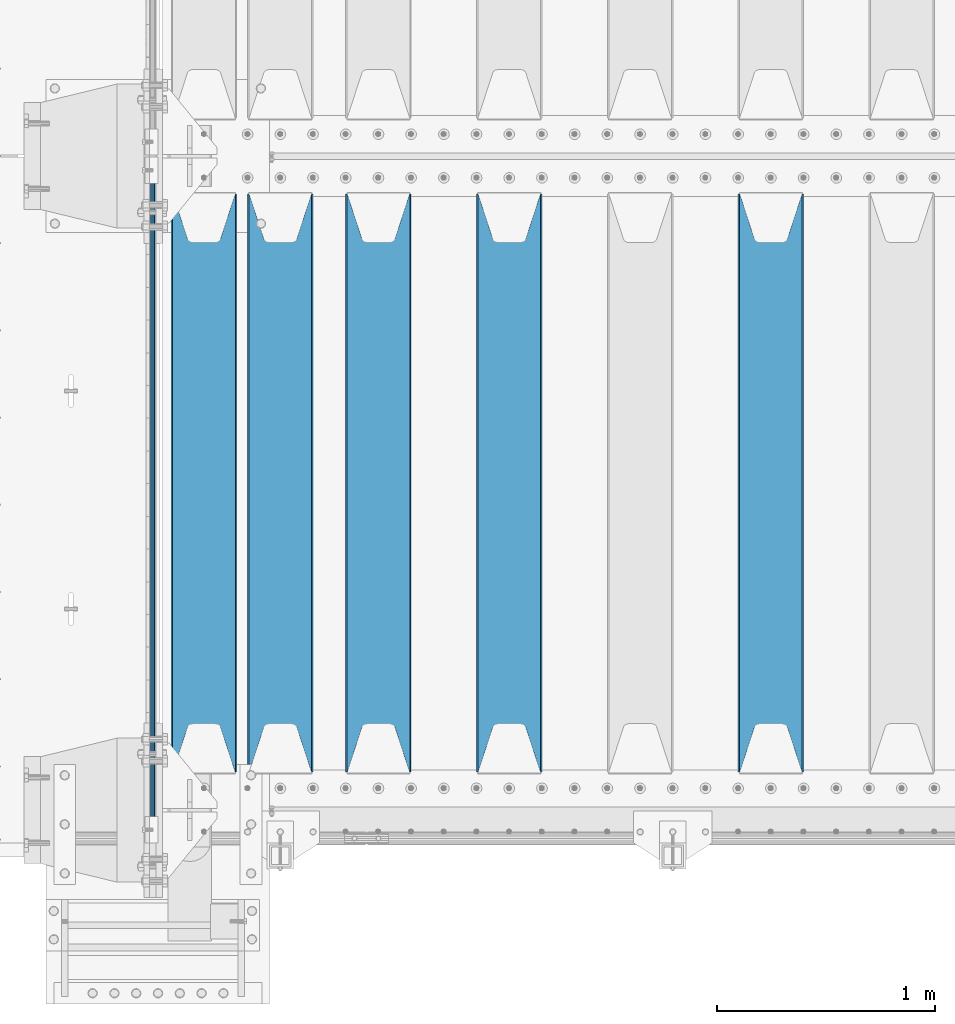
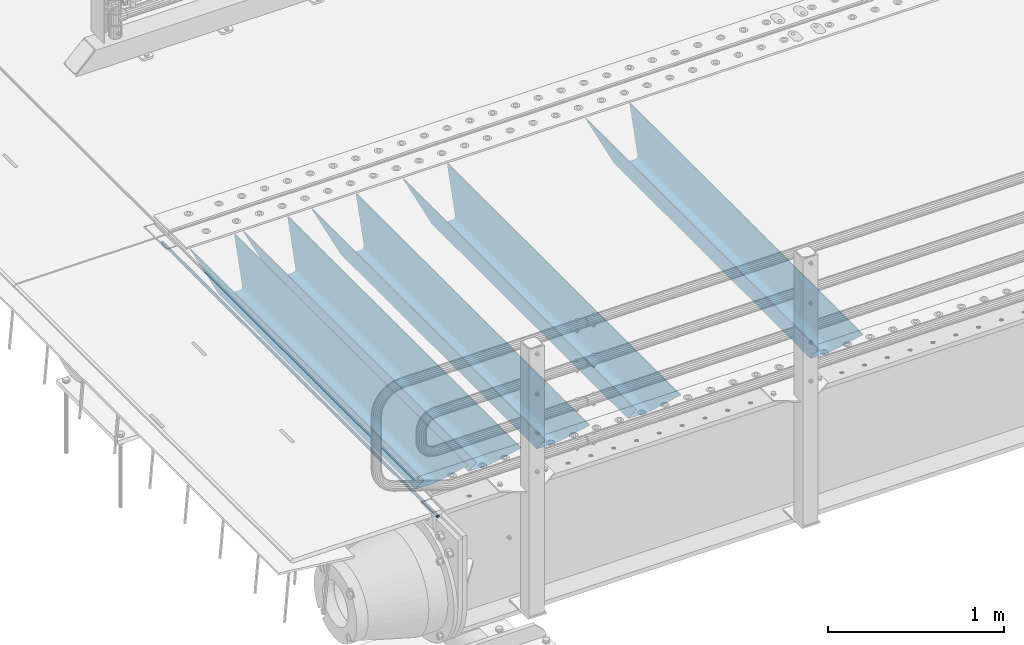
# One storey, part 85 of 193: 6 beams.
"""IFC2X3 building model written with IfcOpenShell, lengths in millimetres."""

from ifc_helpers import new_model, si_unit, frame, origin_with_axes, place, context, subcontext, project, spatial, faceted_brep, material, type_object, element, save


model = new_model("IFC2X3")

# Units and contexts
model_context = context("Model", 3, precision=1e-05, world=origin_with_axes())
body_context = subcontext(model_context, "Body", "Model", "MODEL_VIEW")
ifc_project = project(units=[si_unit("LENGTHUNIT", "METRE", prefix="MILLI"), si_unit("AREAUNIT", "SQUARE_METRE"), si_unit("VOLUMEUNIT", "CUBIC_METRE"), si_unit("MASSUNIT", "GRAM", prefix="KILO"), si_unit("TIMEUNIT", "SECOND"), si_unit("PLANEANGLEUNIT", "RADIAN"), si_unit("SOLIDANGLEUNIT", "STERADIAN"), si_unit("THERMODYNAMICTEMPERATUREUNIT", "DEGREE_CELSIUS"), si_unit("LUMINOUSINTENSITYUNIT", "LUMEN")], contexts=[model_context])

# Site, building, storey
site_placement = place(None, origin_with_axes())
site = spatial("IfcSite", under=ifc_project, at=site_placement, CompositionType="ELEMENT")
building_placement = place(site_placement, origin_with_axes())
building = spatial("IfcBuilding", under=site, at=building_placement, Name="Standard", CompositionType="ELEMENT")
storey_placement = place(building_placement, origin_with_axes())
storey = spatial("IfcBuildingStorey", under=building, at=storey_placement, Name="Undefined", CompositionType="ELEMENT", Elevation=0.0)

# Beams
ifc_material = material(Name="STEEL/S355N")
beam_type_1 = type_object("IfcBeamType", Name="D20", PredefinedType="NOTDEFINED")
beam_1_placement = place(storey_placement, frame((-42485.0, 23850.0, -26.0000191637567), z_axis=(0.0, 0.0, 1.0), x_axis=(0.0, 1.0, 0.0)))
element("IfcBeam", 1, at=beam_1_placement, inside=storey, type_object=beam_type_1, material=ifc_material, ObjectType="D20", context=body_context, shape_type="Brep", body=[
    faceted_brep([(0.0, -10.0, 0.0), (0.0, -7.07106781186303, -7.07106781186548), (3145.0, -7.07106781186303, -7.07106781186548), (3145.0, -10.0, 0.0), (0.0, 0.0, -10.0), (3145.0, 0.0, -10.0), (0.0, 7.07106781186303, -7.07106781186547), (3145.0, 7.07106781186303, -7.07106781186547), (0.0, 10.0, 0.0), (3145.0, 10.0, 0.0), (0.0, 7.07106781186303, 7.07106781186548), (3145.0, 7.07106781186303, 7.07106781186548), (0.0, 0.0, 10.0), (3145.0, 0.0, 10.0), (0.0, -7.07106781186303, 7.07106781186548), (3145.0, -7.07106781186303, 7.07106781186548)], [[[0, 1, 2, 3]], [[1, 4, 5, 2]], [[4, 6, 7, 5]], [[6, 8, 9, 7]], [[8, 10, 11, 9]], [[10, 12, 13, 11]], [[12, 14, 15, 13]], [[14, 0, 3, 15]], [[5, 7, 9, 11, 13, 15, 3, 2]], [[14, 12, 10, 8, 6, 4, 1, 0]]]),
])
beam_type_2 = type_object("IfcBeamType", PredefinedType="NOTDEFINED")
beam_2_placement = place(storey_placement, frame((-39650.0, 24175.0, -115.0), z_axis=(0.0, 0.0, 1.0), x_axis=(0.0, 1.0, 0.0)))
element("IfcBeam", 2, at=beam_2_placement, inside=storey, type_object=beam_type_2, material=ifc_material, context=body_context, shape_type="Brep", body=[
    faceted_brep([(0.0, 150.0, 115.0), (0.0, 143.689999999999, 115.0), (2650.00000000297, 143.689999999999, 115.0), (2650.00000000297, 150.0, 115.0), (2650.00000000297, 142.059565218398, 110.000000003094), (2650.00000000297, 148.3695652184, 110.000000003094), (2441.90079219209, -80.1103600731112, -98.0992078077845), (2437.7588105432, -77.5672621345584, -102.241189456673), (2434.06523489747, -74.4080125315522, -105.934765102404), (2430.9108609509, -70.710272125576, -109.089139048974), (2428.37322971128, -66.5649389910068, -111.626770288588), (2426.51472138055, -62.0739139532889, -113.485278619323), (2425.38102192092, -57.3475956567672, -114.618978078955), (2424.99999999988, -52.5021667386536, -115.0), (2424.99999999988, 52.5021667386536, -115.0), (2425.38102192092, 57.3475956567672, -114.618978078955), (2426.51472138055, 62.0739139532889, -113.485278619323), (2428.37322971128, 66.5649389910068, -111.626770288588), (2430.9108609509, 70.710272125576, -109.089139048974), (2434.06523489747, 74.4080125315522, -105.934765102404), (2437.7588105432, 77.5672621345584, -102.241189456673), (2441.90079219209, 80.1103600731112, -98.0992078077846), (2446.38936140512, 81.9747917625791, -93.6106385947584), (2448.2494850041, 76.2713538057251, -91.7505149957729), (2444.62967112263, 74.76777986261, -95.3703288772456), (2441.28936334127, 72.7168944282894, -98.710636658607), (2438.31067330439, 70.1691124903846, -101.689326695487), (2435.76682334748, 67.1870637758839, -104.233176652398), (2433.72034654134, 63.8440531834895, -106.279653458539), (2432.22154950042, 60.222258798236, -107.778450499454), (2431.30727574265, 56.4107117849089, -108.692724257221), (2430.99999999987, 52.5031078186876, -109.0), (2430.99999999987, -52.5031078186876, -109.0), (2431.30727574265, -56.4107117849089, -108.692724257221), (2432.22154950042, -60.222258798236, -107.778450499454), (2433.72034654134, -63.8440531834895, -106.279653458539), (2435.76682334748, -67.1870637758839, -104.233176652398), (2438.31067330439, -70.1691124903846, -101.689326695487), (2441.28936334127, -72.7168944282894, -98.7106366586071), (2444.62967112263, -74.76777986261, -95.3703288772457), (2448.2494850041, -76.2713538057251, -91.7505149957729), (2650.00000000297, -142.059565218398, 110.000000003094), (2650.00000000297, -148.3695652184, 110.000000003094), (2446.38936140512, -81.9747917625791, -93.6106385947584), (2650.00000000297, -143.689999999999, 115.0), (2650.00000000297, -150.0, 115.0), (0.0, -143.689999999999, 115.0), (0.0, -150.0, 115.0), (0.0, -148.369565218261, 110.000000002667), (203.610638597427, -81.9747917625791, -93.6106385947584), (208.099207810446, -80.1103600731112, -98.0992078077845), (212.241189459342, -77.5672621345584, -102.241189456673), (215.93476510507, -74.4080125315522, -105.934765102404), (219.089139051641, -70.710272125576, -109.089139048974), (221.626770291256, -66.5649389910068, -111.626770288588), (223.485278621989, -62.0739139532889, -113.485278619323), (224.618978081624, -57.3475956567672, -114.618978078955), (225.000000002663, -52.5021667386536, -115.0), (225.000000002663, 52.5021667386536, -115.0), (224.618978081624, 57.3475956567672, -114.618978078955), (223.485278621989, 62.0739139532889, -113.485278619323), (221.626770291256, 66.5649389910068, -111.626770288588), (219.089139051641, 70.710272125576, -109.089139048974), (215.93476510507, 74.4080125315522, -105.934765102404), (212.241189459342, 77.5672621345584, -102.241189456673), (208.099207810446, 80.1103600731112, -98.0992078077846), (203.610638597427, 81.9747917625791, -93.6106385947584), (0.0, 148.369565218261, 110.000000002667), (0.0, 142.05956521826, 110.000000002667), (201.750514998439, 76.2713538057251, -91.7505149957729), (205.370328879915, 74.76777986261, -95.3703288772456), (208.710636661275, 72.7168944282894, -98.710636658607), (211.689326698157, 70.1691124903846, -101.689326695487), (214.233176655063, 67.1870637758839, -104.233176652398), (216.279653461206, 63.8440531834895, -106.279653458539), (217.778450502123, 60.222258798236, -107.778450499454), (218.69272425989, 56.4107117849089, -108.692724257221), (219.00000000267, 52.5031078186876, -109.0), (219.00000000267, -52.5031078186876, -109.0), (218.69272425989, -56.4107117849089, -108.692724257221), (217.778450502123, -60.222258798236, -107.778450499454), (216.279653461206, -63.8440531834895, -106.279653458539), (214.233176655063, -67.1870637758839, -104.233176652398), (211.689326698157, -70.1691124903846, -101.689326695487), (208.710636661275, -72.7168944282894, -98.7106366586071), (205.370328879915, -74.76777986261, -95.3703288772457), (201.750514998439, -76.2713538057251, -91.7505149957729), (0.0, -142.05956521826, 110.000000002667)], [[[0, 1, 2, 3]], [[3, 2, 4, 5]], [[6, 7, 8, 9, 10, 11, 12, 13, 14, 15, 16, 17, 18, 19, 20, 21, 22, 5, 4, 23, 24, 25, 26, 27, 28, 29, 30, 31, 32, 33, 34, 35, 36, 37, 38, 39, 40, 41, 42, 43]], [[44, 45, 42, 41]], [[46, 47, 45, 44]], [[43, 42, 45, 47, 48, 49]], [[6, 43, 49, 50]], [[7, 6, 50, 51]], [[8, 7, 51, 52]], [[9, 8, 52, 53]], [[10, 9, 53, 54]], [[11, 10, 54, 55]], [[12, 11, 55, 56]], [[13, 12, 56, 57]], [[14, 13, 57, 58]], [[15, 14, 58, 59]], [[16, 15, 59, 60]], [[17, 16, 60, 61]], [[18, 17, 61, 62]], [[19, 18, 62, 63]], [[20, 19, 63, 64]], [[21, 20, 64, 65]], [[22, 21, 65, 66]], [[0, 3, 5, 22, 66, 67]], [[1, 0, 67, 68]], [[23, 4, 2, 1, 68, 69]], [[24, 23, 69, 70]], [[25, 24, 70, 71]], [[26, 25, 71, 72]], [[27, 26, 72, 73]], [[28, 27, 73, 74]], [[29, 28, 74, 75]], [[30, 29, 75, 76]], [[31, 30, 76, 77]], [[32, 31, 77, 78]], [[33, 32, 78, 79]], [[34, 33, 79, 80]], [[35, 34, 80, 81]], [[36, 35, 81, 82]], [[37, 36, 82, 83]], [[38, 37, 83, 84]], [[39, 38, 84, 85]], [[40, 39, 85, 86]], [[46, 44, 41, 40, 86, 87]], [[47, 46, 87, 48]], [[86, 85, 84, 83, 82, 81, 80, 79, 78, 77, 76, 75, 74, 73, 72, 71, 70, 69, 68, 67, 66, 65, 64, 63, 62, 61, 60, 59, 58, 57, 56, 55, 54, 53, 52, 51, 50, 49, 48, 87]]]),
])
beam_3_placement = place(storey_placement, frame((-40850.0, 24175.0, -115.0), z_axis=(0.0, 0.0, 1.0), x_axis=(0.0, 1.0, 0.0)))
element("IfcBeam", 3, at=beam_3_placement, inside=storey, type_object=beam_type_2, material=ifc_material, context=body_context, shape_type="Brep", body=[
    faceted_brep([(0.0, 150.0, 115.0), (0.0, 143.689999999999, 115.0), (2650.00000000297, 143.689999999999, 115.0), (2650.00000000297, 150.0, 115.0), (2650.00000000297, 142.059565218398, 110.000000003094), (2650.00000000297, 148.3695652184, 110.000000003094), (2441.90079219209, -80.1103600731112, -98.0992078077845), (2437.7588105432, -77.5672621345584, -102.241189456673), (2434.06523489747, -74.4080125315522, -105.934765102404), (2430.9108609509, -70.710272125576, -109.089139048974), (2428.37322971128, -66.5649389910068, -111.626770288588), (2426.51472138055, -62.0739139532889, -113.485278619323), (2425.38102192092, -57.3475956567672, -114.618978078955), (2424.99999999988, -52.5021667386536, -115.0), (2424.99999999988, 52.5021667386536, -115.0), (2425.38102192092, 57.3475956567672, -114.618978078955), (2426.51472138055, 62.0739139532889, -113.485278619323), (2428.37322971128, 66.5649389910068, -111.626770288588), (2430.9108609509, 70.710272125576, -109.089139048974), (2434.06523489747, 74.4080125315522, -105.934765102404), (2437.7588105432, 77.5672621345584, -102.241189456673), (2441.90079219209, 80.1103600731112, -98.0992078077846), (2446.38936140512, 81.9747917625791, -93.6106385947584), (2448.2494850041, 76.2713538057251, -91.7505149957729), (2444.62967112263, 74.76777986261, -95.3703288772456), (2441.28936334127, 72.7168944282894, -98.710636658607), (2438.31067330439, 70.1691124903846, -101.689326695487), (2435.76682334748, 67.1870637758839, -104.233176652398), (2433.72034654134, 63.8440531834895, -106.279653458539), (2432.22154950042, 60.222258798236, -107.778450499454), (2431.30727574265, 56.4107117849089, -108.692724257221), (2430.99999999987, 52.5031078186876, -109.0), (2430.99999999987, -52.5031078186876, -109.0), (2431.30727574265, -56.4107117849089, -108.692724257221), (2432.22154950042, -60.222258798236, -107.778450499454), (2433.72034654134, -63.8440531834895, -106.279653458539), (2435.76682334748, -67.1870637758839, -104.233176652398), (2438.31067330439, -70.1691124903846, -101.689326695487), (2441.28936334127, -72.7168944282894, -98.7106366586071), (2444.62967112263, -74.76777986261, -95.3703288772457), (2448.2494850041, -76.2713538057251, -91.7505149957729), (2650.00000000297, -142.059565218398, 110.000000003094), (2650.00000000297, -148.3695652184, 110.000000003094), (2446.38936140512, -81.9747917625791, -93.6106385947584), (2650.00000000297, -143.689999999999, 115.0), (2650.00000000297, -150.0, 115.0), (0.0, -143.689999999999, 115.0), (0.0, -150.0, 115.0), (0.0, -148.369565218261, 110.000000002667), (203.610638597427, -81.9747917625791, -93.6106385947584), (208.099207810446, -80.1103600731112, -98.0992078077845), (212.241189459342, -77.5672621345584, -102.241189456673), (215.93476510507, -74.4080125315522, -105.934765102404), (219.089139051641, -70.710272125576, -109.089139048974), (221.626770291256, -66.5649389910068, -111.626770288588), (223.485278621989, -62.0739139532889, -113.485278619323), (224.618978081624, -57.3475956567672, -114.618978078955), (225.000000002663, -52.5021667386536, -115.0), (225.000000002663, 52.5021667386536, -115.0), (224.618978081624, 57.3475956567672, -114.618978078955), (223.485278621989, 62.0739139532889, -113.485278619323), (221.626770291256, 66.5649389910068, -111.626770288588), (219.089139051641, 70.710272125576, -109.089139048974), (215.93476510507, 74.4080125315522, -105.934765102404), (212.241189459342, 77.5672621345584, -102.241189456673), (208.099207810446, 80.1103600731112, -98.0992078077846), (203.610638597427, 81.9747917625791, -93.6106385947584), (0.0, 148.369565218261, 110.000000002667), (0.0, 142.05956521826, 110.000000002667), (201.750514998439, 76.2713538057251, -91.7505149957729), (205.370328879915, 74.76777986261, -95.3703288772456), (208.710636661275, 72.7168944282894, -98.710636658607), (211.689326698157, 70.1691124903846, -101.689326695487), (214.233176655063, 67.1870637758839, -104.233176652398), (216.279653461206, 63.8440531834895, -106.279653458539), (217.778450502123, 60.222258798236, -107.778450499454), (218.69272425989, 56.4107117849089, -108.692724257221), (219.00000000267, 52.5031078186876, -109.0), (219.00000000267, -52.5031078186876, -109.0), (218.69272425989, -56.4107117849089, -108.692724257221), (217.778450502123, -60.222258798236, -107.778450499454), (216.279653461206, -63.8440531834895, -106.279653458539), (214.233176655063, -67.1870637758839, -104.233176652398), (211.689326698157, -70.1691124903846, -101.689326695487), (208.710636661275, -72.7168944282894, -98.7106366586071), (205.370328879915, -74.76777986261, -95.3703288772457), (201.750514998439, -76.2713538057251, -91.7505149957729), (0.0, -142.05956521826, 110.000000002667)], [[[0, 1, 2, 3]], [[3, 2, 4, 5]], [[6, 7, 8, 9, 10, 11, 12, 13, 14, 15, 16, 17, 18, 19, 20, 21, 22, 5, 4, 23, 24, 25, 26, 27, 28, 29, 30, 31, 32, 33, 34, 35, 36, 37, 38, 39, 40, 41, 42, 43]], [[44, 45, 42, 41]], [[46, 47, 45, 44]], [[43, 42, 45, 47, 48, 49]], [[6, 43, 49, 50]], [[7, 6, 50, 51]], [[8, 7, 51, 52]], [[9, 8, 52, 53]], [[10, 9, 53, 54]], [[11, 10, 54, 55]], [[12, 11, 55, 56]], [[13, 12, 56, 57]], [[14, 13, 57, 58]], [[15, 14, 58, 59]], [[16, 15, 59, 60]], [[17, 16, 60, 61]], [[18, 17, 61, 62]], [[19, 18, 62, 63]], [[20, 19, 63, 64]], [[21, 20, 64, 65]], [[22, 21, 65, 66]], [[0, 3, 5, 22, 66, 67]], [[1, 0, 67, 68]], [[23, 4, 2, 1, 68, 69]], [[24, 23, 69, 70]], [[25, 24, 70, 71]], [[26, 25, 71, 72]], [[27, 26, 72, 73]], [[28, 27, 73, 74]], [[29, 28, 74, 75]], [[30, 29, 75, 76]], [[31, 30, 76, 77]], [[32, 31, 77, 78]], [[33, 32, 78, 79]], [[34, 33, 79, 80]], [[35, 34, 80, 81]], [[36, 35, 81, 82]], [[37, 36, 82, 83]], [[38, 37, 83, 84]], [[39, 38, 84, 85]], [[40, 39, 85, 86]], [[46, 44, 41, 40, 86, 87]], [[47, 46, 87, 48]], [[86, 85, 84, 83, 82, 81, 80, 79, 78, 77, 76, 75, 74, 73, 72, 71, 70, 69, 68, 67, 66, 65, 64, 63, 62, 61, 60, 59, 58, 57, 56, 55, 54, 53, 52, 51, 50, 49, 48, 87]]]),
])
beam_4_placement = place(storey_placement, frame((-41450.0, 24175.0, -115.0), z_axis=(0.0, 0.0, 1.0), x_axis=(0.0, 1.0, 0.0)))
element("IfcBeam", 4, at=beam_4_placement, inside=storey, type_object=beam_type_2, material=ifc_material, context=body_context, shape_type="Brep", body=[
    faceted_brep([(0.0, 150.0, 115.0), (0.0, 143.689999999999, 115.0), (2650.00000000297, 143.689999999999, 115.0), (2650.00000000297, 150.0, 115.0), (2650.00000000297, 142.059565218398, 110.000000003094), (2650.00000000297, 148.3695652184, 110.000000003094), (2441.90079219209, -80.1103600731112, -98.0992078077845), (2437.7588105432, -77.5672621345584, -102.241189456673), (2434.06523489747, -74.4080125315522, -105.934765102404), (2430.9108609509, -70.710272125576, -109.089139048974), (2428.37322971128, -66.5649389910068, -111.626770288588), (2426.51472138055, -62.0739139532889, -113.485278619323), (2425.38102192092, -57.3475956567672, -114.618978078955), (2424.99999999988, -52.5021667386536, -115.0), (2424.99999999988, 52.5021667386536, -115.0), (2425.38102192092, 57.3475956567672, -114.618978078955), (2426.51472138055, 62.0739139532889, -113.485278619323), (2428.37322971128, 66.5649389910068, -111.626770288588), (2430.9108609509, 70.710272125576, -109.089139048974), (2434.06523489747, 74.4080125315522, -105.934765102404), (2437.7588105432, 77.5672621345584, -102.241189456673), (2441.90079219209, 80.1103600731112, -98.0992078077846), (2446.38936140512, 81.9747917625791, -93.6106385947584), (2448.2494850041, 76.2713538057251, -91.7505149957729), (2444.62967112263, 74.76777986261, -95.3703288772456), (2441.28936334127, 72.7168944282894, -98.710636658607), (2438.31067330439, 70.1691124903846, -101.689326695487), (2435.76682334748, 67.1870637758839, -104.233176652398), (2433.72034654134, 63.8440531834895, -106.279653458539), (2432.22154950042, 60.222258798236, -107.778450499454), (2431.30727574265, 56.4107117849089, -108.692724257221), (2430.99999999987, 52.5031078186876, -109.0), (2430.99999999987, -52.5031078186876, -109.0), (2431.30727574265, -56.4107117849089, -108.692724257221), (2432.22154950042, -60.222258798236, -107.778450499454), (2433.72034654134, -63.8440531834895, -106.279653458539), (2435.76682334748, -67.1870637758839, -104.233176652398), (2438.31067330439, -70.1691124903846, -101.689326695487), (2441.28936334127, -72.7168944282894, -98.7106366586071), (2444.62967112263, -74.76777986261, -95.3703288772457), (2448.2494850041, -76.2713538057251, -91.7505149957729), (2650.00000000297, -142.059565218398, 110.000000003094), (2650.00000000297, -148.3695652184, 110.000000003094), (2446.38936140512, -81.9747917625791, -93.6106385947584), (2650.00000000297, -143.689999999999, 115.0), (2650.00000000297, -150.0, 115.0), (0.0, -143.689999999999, 115.0), (0.0, -150.0, 115.0), (0.0, -148.369565218261, 110.000000002667), (203.610638597427, -81.9747917625791, -93.6106385947584), (208.099207810446, -80.1103600731112, -98.0992078077845), (212.241189459342, -77.5672621345584, -102.241189456673), (215.93476510507, -74.4080125315522, -105.934765102404), (219.089139051641, -70.710272125576, -109.089139048974), (221.626770291256, -66.5649389910068, -111.626770288588), (223.485278621989, -62.0739139532889, -113.485278619323), (224.618978081624, -57.3475956567672, -114.618978078955), (225.000000002663, -52.5021667386536, -115.0), (225.000000002663, 52.5021667386536, -115.0), (224.618978081624, 57.3475956567672, -114.618978078955), (223.485278621989, 62.0739139532889, -113.485278619323), (221.626770291256, 66.5649389910068, -111.626770288588), (219.089139051641, 70.710272125576, -109.089139048974), (215.93476510507, 74.4080125315522, -105.934765102404), (212.241189459342, 77.5672621345584, -102.241189456673), (208.099207810446, 80.1103600731112, -98.0992078077846), (203.610638597427, 81.9747917625791, -93.6106385947584), (0.0, 148.369565218261, 110.000000002667), (0.0, 142.05956521826, 110.000000002667), (201.750514998439, 76.2713538057251, -91.7505149957729), (205.370328879915, 74.76777986261, -95.3703288772456), (208.710636661275, 72.7168944282894, -98.710636658607), (211.689326698157, 70.1691124903846, -101.689326695487), (214.233176655063, 67.1870637758839, -104.233176652398), (216.279653461206, 63.8440531834895, -106.279653458539), (217.778450502123, 60.222258798236, -107.778450499454), (218.69272425989, 56.4107117849089, -108.692724257221), (219.00000000267, 52.5031078186876, -109.0), (219.00000000267, -52.5031078186876, -109.0), (218.69272425989, -56.4107117849089, -108.692724257221), (217.778450502123, -60.222258798236, -107.778450499454), (216.279653461206, -63.8440531834895, -106.279653458539), (214.233176655063, -67.1870637758839, -104.233176652398), (211.689326698157, -70.1691124903846, -101.689326695487), (208.710636661275, -72.7168944282894, -98.7106366586071), (205.370328879915, -74.76777986261, -95.3703288772457), (201.750514998439, -76.2713538057251, -91.7505149957729), (0.0, -142.05956521826, 110.000000002667)], [[[0, 1, 2, 3]], [[3, 2, 4, 5]], [[6, 7, 8, 9, 10, 11, 12, 13, 14, 15, 16, 17, 18, 19, 20, 21, 22, 5, 4, 23, 24, 25, 26, 27, 28, 29, 30, 31, 32, 33, 34, 35, 36, 37, 38, 39, 40, 41, 42, 43]], [[44, 45, 42, 41]], [[46, 47, 45, 44]], [[43, 42, 45, 47, 48, 49]], [[6, 43, 49, 50]], [[7, 6, 50, 51]], [[8, 7, 51, 52]], [[9, 8, 52, 53]], [[10, 9, 53, 54]], [[11, 10, 54, 55]], [[12, 11, 55, 56]], [[13, 12, 56, 57]], [[14, 13, 57, 58]], [[15, 14, 58, 59]], [[16, 15, 59, 60]], [[17, 16, 60, 61]], [[18, 17, 61, 62]], [[19, 18, 62, 63]], [[20, 19, 63, 64]], [[21, 20, 64, 65]], [[22, 21, 65, 66]], [[0, 3, 5, 22, 66, 67]], [[1, 0, 67, 68]], [[23, 4, 2, 1, 68, 69]], [[24, 23, 69, 70]], [[25, 24, 70, 71]], [[26, 25, 71, 72]], [[27, 26, 72, 73]], [[28, 27, 73, 74]], [[29, 28, 74, 75]], [[30, 29, 75, 76]], [[31, 30, 76, 77]], [[32, 31, 77, 78]], [[33, 32, 78, 79]], [[34, 33, 79, 80]], [[35, 34, 80, 81]], [[36, 35, 81, 82]], [[37, 36, 82, 83]], [[38, 37, 83, 84]], [[39, 38, 84, 85]], [[40, 39, 85, 86]], [[46, 44, 41, 40, 86, 87]], [[47, 46, 87, 48]], [[86, 85, 84, 83, 82, 81, 80, 79, 78, 77, 76, 75, 74, 73, 72, 71, 70, 69, 68, 67, 66, 65, 64, 63, 62, 61, 60, 59, 58, 57, 56, 55, 54, 53, 52, 51, 50, 49, 48, 87]]]),
])
beam_5_placement = place(storey_placement, frame((-41900.0, 24175.0, -115.0), z_axis=(0.0, 0.0, 1.0), x_axis=(0.0, 1.0, 0.0)))
element("IfcBeam", 5, at=beam_5_placement, inside=storey, type_object=beam_type_2, material=ifc_material, context=body_context, shape_type="Brep", body=[
    faceted_brep([(0.0, 150.0, 115.0), (0.0, 143.689999999999, 115.0), (2650.00000000297, 143.689999999999, 115.0), (2650.00000000297, 150.0, 115.0), (2650.00000000297, 142.059565218398, 110.000000003094), (2650.00000000297, 148.3695652184, 110.000000003094), (2441.90079219209, -80.1103600731112, -98.0992078077845), (2437.7588105432, -77.5672621345584, -102.241189456673), (2434.06523489747, -74.4080125315522, -105.934765102404), (2430.9108609509, -70.710272125576, -109.089139048974), (2428.37322971128, -66.5649389910068, -111.626770288588), (2426.51472138055, -62.0739139532889, -113.485278619323), (2425.38102192092, -57.3475956567672, -114.618978078955), (2424.99999999988, -52.5021667386536, -115.0), (2424.99999999988, 52.5021667386536, -115.0), (2425.38102192092, 57.3475956567672, -114.618978078955), (2426.51472138055, 62.0739139532889, -113.485278619323), (2428.37322971128, 66.5649389910068, -111.626770288588), (2430.9108609509, 70.710272125576, -109.089139048974), (2434.06523489747, 74.4080125315522, -105.934765102404), (2437.7588105432, 77.5672621345584, -102.241189456673), (2441.90079219209, 80.1103600731112, -98.0992078077846), (2446.38936140512, 81.9747917625791, -93.6106385947584), (2448.2494850041, 76.2713538057251, -91.7505149957729), (2444.62967112263, 74.76777986261, -95.3703288772456), (2441.28936334127, 72.7168944282894, -98.710636658607), (2438.31067330439, 70.1691124903846, -101.689326695487), (2435.76682334748, 67.1870637758839, -104.233176652398), (2433.72034654134, 63.8440531834895, -106.279653458539), (2432.22154950042, 60.222258798236, -107.778450499454), (2431.30727574265, 56.4107117849089, -108.692724257221), (2430.99999999987, 52.5031078186876, -109.0), (2430.99999999987, -52.5031078186876, -109.0), (2431.30727574265, -56.4107117849089, -108.692724257221), (2432.22154950042, -60.222258798236, -107.778450499454), (2433.72034654134, -63.8440531834895, -106.279653458539), (2435.76682334748, -67.1870637758839, -104.233176652398), (2438.31067330439, -70.1691124903846, -101.689326695487), (2441.28936334127, -72.7168944282894, -98.7106366586071), (2444.62967112263, -74.76777986261, -95.3703288772457), (2448.2494850041, -76.2713538057251, -91.7505149957729), (2650.00000000297, -142.059565218398, 110.000000003094), (2650.00000000297, -148.3695652184, 110.000000003094), (2446.38936140512, -81.9747917625791, -93.6106385947584), (2650.00000000297, -143.689999999999, 115.0), (2650.00000000297, -150.0, 115.0), (0.0, -143.689999999999, 115.0), (0.0, -150.0, 115.0), (0.0, -148.369565218261, 110.000000002667), (203.610638597427, -81.9747917625791, -93.6106385947584), (208.099207810446, -80.1103600731112, -98.0992078077845), (212.241189459342, -77.5672621345584, -102.241189456673), (215.93476510507, -74.4080125315522, -105.934765102404), (219.089139051641, -70.710272125576, -109.089139048974), (221.626770291256, -66.5649389910068, -111.626770288588), (223.485278621989, -62.0739139532889, -113.485278619323), (224.618978081624, -57.3475956567672, -114.618978078955), (225.000000002663, -52.5021667386536, -115.0), (225.000000002663, 52.5021667386536, -115.0), (224.618978081624, 57.3475956567672, -114.618978078955), (223.485278621989, 62.0739139532889, -113.485278619323), (221.626770291256, 66.5649389910068, -111.626770288588), (219.089139051641, 70.710272125576, -109.089139048974), (215.93476510507, 74.4080125315522, -105.934765102404), (212.241189459342, 77.5672621345584, -102.241189456673), (208.099207810446, 80.1103600731112, -98.0992078077846), (203.610638597427, 81.9747917625791, -93.6106385947584), (0.0, 148.369565218261, 110.000000002667), (0.0, 142.05956521826, 110.000000002667), (201.750514998439, 76.2713538057251, -91.7505149957729), (205.370328879915, 74.76777986261, -95.3703288772456), (208.710636661275, 72.7168944282894, -98.710636658607), (211.689326698157, 70.1691124903846, -101.689326695487), (214.233176655063, 67.1870637758839, -104.233176652398), (216.279653461206, 63.8440531834895, -106.279653458539), (217.778450502123, 60.222258798236, -107.778450499454), (218.69272425989, 56.4107117849089, -108.692724257221), (219.00000000267, 52.5031078186876, -109.0), (219.00000000267, -52.5031078186876, -109.0), (218.69272425989, -56.4107117849089, -108.692724257221), (217.778450502123, -60.222258798236, -107.778450499454), (216.279653461206, -63.8440531834895, -106.279653458539), (214.233176655063, -67.1870637758839, -104.233176652398), (211.689326698157, -70.1691124903846, -101.689326695487), (208.710636661275, -72.7168944282894, -98.7106366586071), (205.370328879915, -74.76777986261, -95.3703288772457), (201.750514998439, -76.2713538057251, -91.7505149957729), (0.0, -142.05956521826, 110.000000002667)], [[[0, 1, 2, 3]], [[3, 2, 4, 5]], [[6, 7, 8, 9, 10, 11, 12, 13, 14, 15, 16, 17, 18, 19, 20, 21, 22, 5, 4, 23, 24, 25, 26, 27, 28, 29, 30, 31, 32, 33, 34, 35, 36, 37, 38, 39, 40, 41, 42, 43]], [[44, 45, 42, 41]], [[46, 47, 45, 44]], [[43, 42, 45, 47, 48, 49]], [[6, 43, 49, 50]], [[7, 6, 50, 51]], [[8, 7, 51, 52]], [[9, 8, 52, 53]], [[10, 9, 53, 54]], [[11, 10, 54, 55]], [[12, 11, 55, 56]], [[13, 12, 56, 57]], [[14, 13, 57, 58]], [[15, 14, 58, 59]], [[16, 15, 59, 60]], [[17, 16, 60, 61]], [[18, 17, 61, 62]], [[19, 18, 62, 63]], [[20, 19, 63, 64]], [[21, 20, 64, 65]], [[22, 21, 65, 66]], [[0, 3, 5, 22, 66, 67]], [[1, 0, 67, 68]], [[23, 4, 2, 1, 68, 69]], [[24, 23, 69, 70]], [[25, 24, 70, 71]], [[26, 25, 71, 72]], [[27, 26, 72, 73]], [[28, 27, 73, 74]], [[29, 28, 74, 75]], [[30, 29, 75, 76]], [[31, 30, 76, 77]], [[32, 31, 77, 78]], [[33, 32, 78, 79]], [[34, 33, 79, 80]], [[35, 34, 80, 81]], [[36, 35, 81, 82]], [[37, 36, 82, 83]], [[38, 37, 83, 84]], [[39, 38, 84, 85]], [[40, 39, 85, 86]], [[46, 44, 41, 40, 86, 87]], [[47, 46, 87, 48]], [[86, 85, 84, 83, 82, 81, 80, 79, 78, 77, 76, 75, 74, 73, 72, 71, 70, 69, 68, 67, 66, 65, 64, 63, 62, 61, 60, 59, 58, 57, 56, 55, 54, 53, 52, 51, 50, 49, 48, 87]]]),
])
beam_6_placement = place(storey_placement, frame((-42250.0, 24175.0, -115.0), z_axis=(0.0, 0.0, 1.0), x_axis=(0.0, 1.0, 0.0)))
element("IfcBeam", 6, at=beam_6_placement, inside=storey, type_object=beam_type_2, material=ifc_material, context=body_context, shape_type="Brep", body=[
    faceted_brep([(0.0, 150.0, 115.0), (0.0, 143.689999999999, 115.0), (2650.00000000297, 143.689999999999, 115.0), (2650.00000000297, 150.0, 115.0), (2650.00000000297, 142.059565218398, 110.000000003094), (2650.00000000297, 148.3695652184, 110.000000003094), (2441.90079219209, -80.1103600731112, -98.0992078077845), (2437.7588105432, -77.5672621345584, -102.241189456673), (2434.06523489747, -74.4080125315522, -105.934765102404), (2430.9108609509, -70.710272125576, -109.089139048974), (2428.37322971128, -66.5649389910068, -111.626770288588), (2426.51472138055, -62.0739139532889, -113.485278619323), (2425.38102192092, -57.3475956567672, -114.618978078955), (2424.99999999988, -52.5021667386536, -115.0), (2424.99999999988, 52.5021667386536, -115.0), (2425.38102192092, 57.3475956567672, -114.618978078955), (2426.51472138055, 62.0739139532889, -113.485278619323), (2428.37322971128, 66.5649389910068, -111.626770288588), (2430.9108609509, 70.710272125576, -109.089139048974), (2434.06523489747, 74.4080125315522, -105.934765102404), (2437.7588105432, 77.5672621345584, -102.241189456673), (2441.90079219209, 80.1103600731112, -98.0992078077846), (2446.38936140512, 81.9747917625791, -93.6106385947584), (2448.2494850041, 76.2713538057251, -91.7505149957729), (2444.62967112263, 74.76777986261, -95.3703288772456), (2441.28936334127, 72.7168944282894, -98.710636658607), (2438.31067330439, 70.1691124903846, -101.689326695487), (2435.76682334748, 67.1870637758839, -104.233176652398), (2433.72034654134, 63.8440531834895, -106.279653458539), (2432.22154950042, 60.222258798236, -107.778450499454), (2431.30727574265, 56.4107117849089, -108.692724257221), (2430.99999999987, 52.5031078186876, -109.0), (2430.99999999987, -52.5031078186876, -109.0), (2431.30727574265, -56.4107117849089, -108.692724257221), (2432.22154950042, -60.222258798236, -107.778450499454), (2433.72034654134, -63.8440531834895, -106.279653458539), (2435.76682334748, -67.1870637758839, -104.233176652398), (2438.31067330439, -70.1691124903846, -101.689326695487), (2441.28936334127, -72.7168944282894, -98.7106366586071), (2444.62967112263, -74.76777986261, -95.3703288772457), (2448.2494850041, -76.2713538057251, -91.7505149957729), (2650.00000000297, -142.059565218398, 110.000000003094), (2650.00000000297, -148.3695652184, 110.000000003094), (2446.38936140512, -81.9747917625791, -93.6106385947584), (2650.00000000297, -143.689999999999, 115.0), (2650.00000000297, -150.0, 115.0), (0.0, -143.689999999999, 115.0), (0.0, -150.0, 115.0), (0.0, -148.369565218261, 110.000000002667), (203.610638597427, -81.9747917625791, -93.6106385947584), (208.099207810446, -80.1103600731112, -98.0992078077845), (212.241189459342, -77.5672621345584, -102.241189456673), (215.93476510507, -74.4080125315522, -105.934765102404), (219.089139051641, -70.710272125576, -109.089139048974), (221.626770291256, -66.5649389910068, -111.626770288588), (223.485278621989, -62.0739139532889, -113.485278619323), (224.618978081624, -57.3475956567672, -114.618978078955), (225.000000002663, -52.5021667386536, -115.0), (225.000000002663, 52.5021667386536, -115.0), (224.618978081624, 57.3475956567672, -114.618978078955), (223.485278621989, 62.0739139532889, -113.485278619323), (221.626770291256, 66.5649389910068, -111.626770288588), (219.089139051641, 70.710272125576, -109.089139048974), (215.93476510507, 74.4080125315522, -105.934765102404), (212.241189459342, 77.5672621345584, -102.241189456673), (208.099207810446, 80.1103600731112, -98.0992078077846), (203.610638597427, 81.9747917625791, -93.6106385947584), (0.0, 148.369565218261, 110.000000002667), (0.0, 142.05956521826, 110.000000002667), (201.750514998439, 76.2713538057251, -91.7505149957729), (205.370328879915, 74.76777986261, -95.3703288772456), (208.710636661275, 72.7168944282894, -98.710636658607), (211.689326698157, 70.1691124903846, -101.689326695487), (214.233176655063, 67.1870637758839, -104.233176652398), (216.279653461206, 63.8440531834895, -106.279653458539), (217.778450502123, 60.222258798236, -107.778450499454), (218.69272425989, 56.4107117849089, -108.692724257221), (219.00000000267, 52.5031078186876, -109.0), (219.00000000267, -52.5031078186876, -109.0), (218.69272425989, -56.4107117849089, -108.692724257221), (217.778450502123, -60.222258798236, -107.778450499454), (216.279653461206, -63.8440531834895, -106.279653458539), (214.233176655063, -67.1870637758839, -104.233176652398), (211.689326698157, -70.1691124903846, -101.689326695487), (208.710636661275, -72.7168944282894, -98.7106366586071), (205.370328879915, -74.76777986261, -95.3703288772457), (201.750514998439, -76.2713538057251, -91.7505149957729), (0.0, -142.05956521826, 110.000000002667)], [[[0, 1, 2, 3]], [[3, 2, 4, 5]], [[6, 7, 8, 9, 10, 11, 12, 13, 14, 15, 16, 17, 18, 19, 20, 21, 22, 5, 4, 23, 24, 25, 26, 27, 28, 29, 30, 31, 32, 33, 34, 35, 36, 37, 38, 39, 40, 41, 42, 43]], [[44, 45, 42, 41]], [[46, 47, 45, 44]], [[43, 42, 45, 47, 48, 49]], [[6, 43, 49, 50]], [[7, 6, 50, 51]], [[8, 7, 51, 52]], [[9, 8, 52, 53]], [[10, 9, 53, 54]], [[11, 10, 54, 55]], [[12, 11, 55, 56]], [[13, 12, 56, 57]], [[14, 13, 57, 58]], [[15, 14, 58, 59]], [[16, 15, 59, 60]], [[17, 16, 60, 61]], [[18, 17, 61, 62]], [[19, 18, 62, 63]], [[20, 19, 63, 64]], [[21, 20, 64, 65]], [[22, 21, 65, 66]], [[0, 3, 5, 22, 66, 67]], [[1, 0, 67, 68]], [[23, 4, 2, 1, 68, 69]], [[24, 23, 69, 70]], [[25, 24, 70, 71]], [[26, 25, 71, 72]], [[27, 26, 72, 73]], [[28, 27, 73, 74]], [[29, 28, 74, 75]], [[30, 29, 75, 76]], [[31, 30, 76, 77]], [[32, 31, 77, 78]], [[33, 32, 78, 79]], [[34, 33, 79, 80]], [[35, 34, 80, 81]], [[36, 35, 81, 82]], [[37, 36, 82, 83]], [[38, 37, 83, 84]], [[39, 38, 84, 85]], [[40, 39, 85, 86]], [[46, 44, 41, 40, 86, 87]], [[47, 46, 87, 48]], [[86, 85, 84, 83, 82, 81, 80, 79, 78, 77, 76, 75, 74, 73, 72, 71, 70, 69, 68, 67, 66, 65, 64, 63, 62, 61, 60, 59, 58, 57, 56, 55, 54, 53, 52, 51, 50, 49, 48, 87]]]),
])

save(model, "model.ifc")
